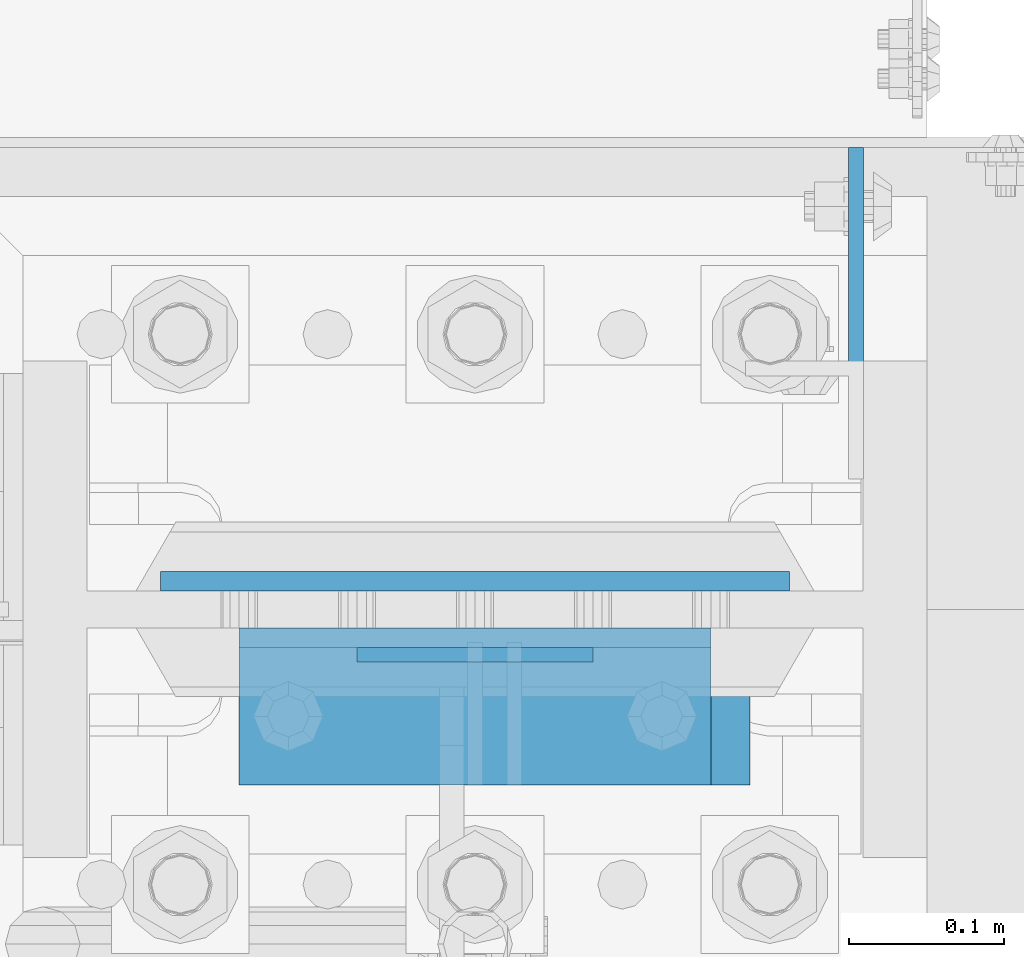
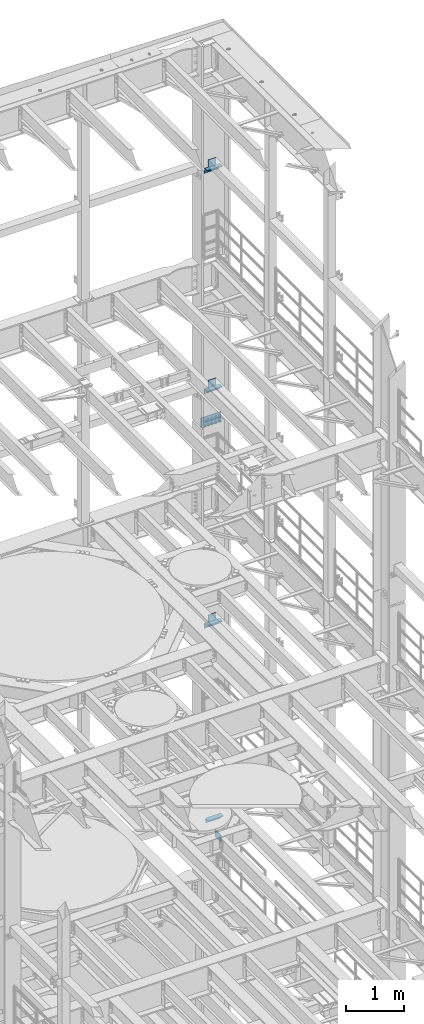
# One storey, part 1354 of 1876: 12 beams, 5 elements without a shape of their own.
"""IFC2X3 building model written with IfcOpenShell, lengths in millimetres."""

from ifc_helpers import new_model, si_unit, frame, origin_with_axes, place, context, subcontext, project, spatial, faceted_brep, material, type_object, element, aggregate, save


model = new_model("IFC2X3")

# Units and contexts
model_context = context("Model", 3, precision=1e-05, world=origin_with_axes())
body_context = subcontext(model_context, "Body", "Model", "MODEL_VIEW")
ifc_project = project(units=[si_unit("LENGTHUNIT", "METRE", prefix="MILLI"), si_unit("AREAUNIT", "SQUARE_METRE"), si_unit("VOLUMEUNIT", "CUBIC_METRE"), si_unit("MASSUNIT", "GRAM", prefix="KILO"), si_unit("TIMEUNIT", "SECOND"), si_unit("PLANEANGLEUNIT", "RADIAN"), si_unit("SOLIDANGLEUNIT", "STERADIAN"), si_unit("THERMODYNAMICTEMPERATUREUNIT", "DEGREE_CELSIUS"), si_unit("LUMINOUSINTENSITYUNIT", "LUMEN")], contexts=[model_context])

# Site, building, storey
site_placement = place(None, origin_with_axes())
site = spatial("IfcSite", under=ifc_project, at=site_placement, CompositionType="ELEMENT")
building_placement = place(site_placement, origin_with_axes())
building = spatial("IfcBuilding", under=site, at=building_placement, Name="Undefined", CompositionType="ELEMENT")
storey_placement = place(building_placement, origin_with_axes())
storey = spatial("IfcBuildingStorey", under=building, at=storey_placement, Name="Undefined", CompositionType="ELEMENT", Elevation=0.0)

# Assembly, beam
assembly_1_placement = place(storey_placement, origin_with_axes())
assembly_1 = element("IfcElementAssembly", 1, at=assembly_1_placement, inside=storey, Name="COLUMN", AssemblyPlace="NOTDEFINED", PredefinedType="RIGID_FRAME")
ifc_material_1 = material(Name="STEEL/A36")
beam_type_1 = type_object("IfcBeamType", PredefinedType="NOTDEFINED")
beam_1_placement = place(assembly_1_placement, frame((7866.20421670226, 13800.1375001356, 5613.4), z_axis=(0.0, 0.0, -1.0), x_axis=(0.0, 1.0, 0.0)))
beam_1 = element("IfcBeam", 2, at=beam_1_placement, type_object=beam_type_1, material=ifc_material_1, Name="PLATE", context=body_context, shape_type="Brep", body=[
    faceted_brep([(0.0, 4.76249999999982, -76.1999999999998), (3.63797880709171e-12, 4.76249999999982, 76.1999969482422), (214.312499998445, 4.76249999993797, 76.2000000000007), (214.312499998445, 4.76249999993797, -76.2000000000007), (3.63797880709171e-12, -4.76249999999982, 76.1999969482422), (214.312499998441, -4.76250000006257, 76.2000000000007), (0.0, -4.76249999999982, -76.1999999999998), (214.312499998441, -4.76250000006257, -76.2000000000007)], [[[0, 1, 2, 3]], [[1, 4, 5, 2]], [[4, 6, 7, 5]], [[6, 0, 3, 7]], [[5, 7, 3, 2]], [[6, 4, 1, 0]]]),
])

assembly_2_placement = place(storey_placement, origin_with_axes())
assembly_2 = element("IfcElementAssembly", 3, at=assembly_2_placement, inside=storey, Name="BEAM", AssemblyPlace="NOTDEFINED", PredefinedType="RIGID_FRAME")
beam_2_placement = place(assembly_2_placement, frame((7696.2, 13686.63125, 19958.05), z_axis=(0.0, 0.0, -1.0), x_axis=(-1.0, 0.0, 0.0)))
beam_2 = element("IfcBeam", 4, at=beam_2_placement, type_object=beam_type_1, material=ifc_material_1, Name="PLATE", context=body_context, shape_type="Brep", body=[
    faceted_brep([(0.0, 4.76249999999982, -76.1999999999998), (3.63797880709171e-12, 4.76249999999982, 76.1999969482422), (152.399993896484, 4.76250000000073, 76.1999969482422), (152.4, 4.76249999999982, -76.1999999999998), (3.63797880709171e-12, -4.76249999999982, 76.1999969482422), (152.399993896484, -4.76250000000073, 76.1999969482422), (0.0, -4.76249999999982, -76.1999999999998), (152.4, -4.76249999999982, -76.1999999999998)], [[[0, 1, 2, 3]], [[4, 5, 2, 1]], [[4, 6, 7, 5]], [[6, 0, 3, 7]], [[5, 7, 3, 2]], [[6, 4, 1, 0]]]),
])

assembly_3_placement = place(storey_placement, origin_with_axes())
assembly_3 = element("IfcElementAssembly", 5, at=assembly_3_placement, inside=storey, Name="BEAM", AssemblyPlace="NOTDEFINED", PredefinedType="RIGID_FRAME")
beam_3_placement = place(assembly_3_placement, frame((7696.2, 13686.63125, 15335.25), z_axis=(0.0, 0.0, -1.0), x_axis=(-1.0, 0.0, 0.0)))
beam_3 = element("IfcBeam", 6, at=beam_3_placement, type_object=beam_type_1, material=ifc_material_1, Name="PLATE", context=body_context, shape_type="Brep", body=[
    faceted_brep([(0.0, 4.76249999999982, -76.1999999999998), (3.63797880709171e-12, 4.76249999999982, 76.1999969482422), (152.399993896484, 4.76250000000073, 76.1999969482422), (152.4, 4.76249999999982, -76.1999999999998), (3.63797880709171e-12, -4.76249999999982, 76.1999969482422), (152.399993896484, -4.76250000000073, 76.1999969482422), (0.0, -4.76249999999982, -76.1999999999998), (152.4, -4.76249999999982, -76.1999999999998)], [[[0, 1, 2, 3]], [[4, 5, 2, 1]], [[4, 6, 7, 5]], [[6, 0, 3, 7]], [[5, 7, 3, 2]], [[6, 4, 1, 0]]]),
])

assembly_4_placement = place(storey_placement, origin_with_axes())
assembly_4 = element("IfcElementAssembly", 7, at=assembly_4_placement, inside=storey, Name="BEAM", AssemblyPlace="NOTDEFINED", PredefinedType="RIGID_FRAME")
beam_4_placement = place(assembly_4_placement, frame((7696.2, 13686.63125, 10420.35), z_axis=(0.0, 0.0, -1.0), x_axis=(-1.0, 0.0, 0.0)))
beam_4 = element("IfcBeam", 8, at=beam_4_placement, type_object=beam_type_1, material=ifc_material_1, Name="PLATE", context=body_context, shape_type="Brep", body=[
    faceted_brep([(0.0, 4.76249999999982, -76.1999999999998), (3.63797880709171e-12, 4.76249999999982, 76.1999969482422), (152.399993896484, 4.76250000000073, 76.1999969482422), (152.4, 4.76249999999982, -76.1999999999998), (3.63797880709171e-12, -4.76249999999982, 76.1999969482422), (152.399993896484, -4.76250000000073, 76.1999969482422), (0.0, -4.76249999999982, -76.1999999999998), (152.4, -4.76249999999982, -76.1999999999998)], [[[0, 1, 2, 3]], [[4, 5, 2, 1]], [[4, 6, 7, 5]], [[6, 0, 3, 7]], [[5, 7, 3, 2]], [[6, 4, 1, 0]]]),
])

# Beam
beam_type_2 = type_object("IfcBeamType", PredefinedType="NOTDEFINED")
beam_5_placement = place(assembly_2_placement, frame((7467.6, 13646.94375, 19877.0875), z_axis=(0.0, -1.0, 0.0), x_axis=(1.0, 0.0, 0.0)))
beam_5 = element("IfcBeam", 9, at=beam_5_placement, type_object=beam_type_2, material=ifc_material_1, Name="PLATE", context=body_context, shape_type="Brep", body=[
    faceted_brep([(0.0, 4.76250000000073, -44.4499999999998), (0.0, 4.76250000000073, 44.4499999999998), (304.799999999999, 4.76250000000073, 44.4499999999998), (304.799999999999, 4.76250000000073, -44.4499999999998), (0.0, -4.76250000000073, 44.4499999999998), (304.799999999999, -4.76250000000073, 44.4499999999998), (0.0, -4.76250000000073, -44.4499999999998), (304.799999999999, -4.76250000000073, -44.4499999999998)], [[[0, 1, 2, 3]], [[1, 4, 5, 2]], [[4, 6, 7, 5]], [[6, 0, 3, 7]], [[5, 7, 3, 2]], [[6, 4, 1, 0]]]),
])

aggregate(assembly_2, [beam_2, beam_5])

beam_6_placement = place(assembly_3_placement, frame((7467.6, 13646.94375, 15254.2875), z_axis=(0.0, -1.0, 0.0), x_axis=(1.0, 0.0, 0.0)))
beam_6 = element("IfcBeam", 10, at=beam_6_placement, type_object=beam_type_2, material=ifc_material_1, Name="PLATE", context=body_context, shape_type="Brep", body=[
    faceted_brep([(0.0, 4.76250000000073, -44.4499999999998), (0.0, 4.76250000000073, 44.4499999999998), (304.799999999999, 4.76250000000073, 44.4499999999998), (304.799999999999, 4.76250000000073, -44.4499999999998), (0.0, -4.76250000000073, 44.4499999999998), (304.799999999999, -4.76250000000073, 44.4499999999998), (0.0, -4.76250000000073, -44.4499999999998), (304.799999999999, -4.76250000000073, -44.4499999999998)], [[[0, 1, 2, 3]], [[1, 4, 5, 2]], [[4, 6, 7, 5]], [[6, 0, 3, 7]], [[5, 7, 3, 2]], [[6, 4, 1, 0]]]),
])

aggregate(assembly_3, [beam_3, beam_6])

beam_7_placement = place(assembly_4_placement, frame((7467.6, 13646.94375, 10339.3875), z_axis=(0.0, -1.0, 0.0), x_axis=(1.0, 0.0, 0.0)))
beam_7 = element("IfcBeam", 11, at=beam_7_placement, type_object=beam_type_2, material=ifc_material_1, Name="PLATE", context=body_context, shape_type="Brep", body=[
    faceted_brep([(0.0, 4.76250000000073, -44.4499999999998), (0.0, 4.76250000000073, 44.4499999999998), (304.799999999999, 4.76250000000073, 44.4499999999998), (304.799999999999, 4.76250000000073, -44.4499999999998), (0.0, -4.76250000000073, 44.4499999999998), (304.799999999999, -4.76250000000073, 44.4499999999998), (0.0, -4.76250000000073, -44.4499999999998), (304.799999999999, -4.76250000000073, -44.4499999999998)], [[[0, 1, 2, 3]], [[1, 4, 5, 2]], [[4, 6, 7, 5]], [[6, 0, 3, 7]], [[5, 7, 3, 2]], [[6, 4, 1, 0]]]),
])

aggregate(assembly_4, [beam_4, beam_7])

# Assembly, beams
assembly_5_placement = place(storey_placement, origin_with_axes())
assembly_5 = element("IfcElementAssembly", 12, at=assembly_5_placement, inside=storey, Name="COLUMN", AssemblyPlace="NOTDEFINED", PredefinedType="RIGID_FRAME")
beam_type_3 = type_object("IfcBeamType", Name="L4X4X3/8", PredefinedType="NOTDEFINED")
beam_8_placement = place(assembly_5_placement, frame((7467.6, 13653.29375, 19821.525), z_axis=(0.0, -1.0, 0.0), x_axis=(1.0, 0.0, 0.0)))
beam_8 = element("IfcBeam", 13, at=beam_8_placement, type_object=beam_type_3, material=ifc_material_1, Name="ANGLE", ObjectType="L4X4X3/8", context=body_context, shape_type="Brep", body=[
    faceted_brep([(0.0, 50.7999999999993, -50.8000000000002), (0.0, 50.7999999999993, 50.8000000000002), (304.799999999999, 50.7999999999993, 50.8000000000002), (304.799999999999, 50.7999999999993, -50.8000000000002), (0.0, 41.2750000000015, 50.8000000000002), (304.799999999999, 41.2750000000015, 50.8000000000002), (0.0, 41.2750000000015, -41.2749999999996), (304.799999999999, 41.2750000000015, -41.2749999999996), (0.0, -50.7999999999993, -41.2749999999996), (304.799999999999, -50.7999999999993, -41.2749999999996), (0.0, -50.7999999999993, -50.8000000000002), (304.799999999999, -50.7999999999993, -50.8000000000002)], [[[0, 1, 2, 3]], [[1, 4, 5, 2]], [[4, 6, 7, 5]], [[6, 8, 9, 7]], [[8, 10, 11, 9]], [[10, 0, 3, 11]], [[5, 7, 9, 11, 3, 2]], [[10, 8, 6, 4, 1, 0]]]),
])
beam_9_placement = place(assembly_5_placement, frame((7467.6, 13653.29375, 15198.725), z_axis=(0.0, -1.0, 0.0), x_axis=(1.0, 0.0, 0.0)))
beam_9 = element("IfcBeam", 14, at=beam_9_placement, type_object=beam_type_3, material=ifc_material_1, Name="ANGLE", ObjectType="L4X4X3/8", context=body_context, shape_type="Brep", body=[
    faceted_brep([(0.0, 50.7999999999993, -50.8000000000002), (0.0, 50.7999999999993, 50.8000000000002), (304.799999999999, 50.7999999999993, 50.8000000000002), (304.799999999999, 50.7999999999993, -50.8000000000002), (0.0, 41.2750000000015, 50.8000000000002), (304.799999999999, 41.2750000000015, 50.8000000000002), (0.0, 41.2750000000015, -41.2749999999996), (304.799999999999, 41.2750000000015, -41.2749999999996), (0.0, -50.7999999999993, -41.2749999999996), (304.799999999999, -50.7999999999993, -41.2749999999996), (0.0, -50.7999999999993, -50.8000000000002), (304.799999999999, -50.7999999999993, -50.8000000000002)], [[[0, 1, 2, 3]], [[1, 4, 5, 2]], [[4, 6, 7, 5]], [[6, 8, 9, 7]], [[8, 10, 11, 9]], [[10, 0, 3, 11]], [[5, 7, 9, 11, 3, 2]], [[10, 8, 6, 4, 1, 0]]]),
])
aggregate(assembly_5, [beam_8, beam_9])

# Beam
beam_10_placement = place(assembly_1_placement, frame((7467.6, 13653.29375, 10283.825), z_axis=(0.0, -1.0, 0.0), x_axis=(1.0, 0.0, 0.0)))
beam_10 = element("IfcBeam", 15, at=beam_10_placement, type_object=beam_type_3, material=ifc_material_1, Name="ANGLE", ObjectType="L4X4X3/8", context=body_context, shape_type="Brep", body=[
    faceted_brep([(0.0, 50.7999999999993, -50.8000000000002), (0.0, 50.7999999999993, 50.8000000000002), (304.799999999999, 50.7999999999993, 50.8000000000002), (304.799999999999, 50.7999999999993, -50.8000000000002), (0.0, 41.2750000000015, 50.8000000000002), (304.799999999999, 41.2750000000015, 50.8000000000002), (0.0, 41.2750000000015, -41.2749999999996), (304.799999999999, 41.2750000000015, -41.2749999999996), (0.0, -50.7999999999993, -41.2749999999996), (304.799999999999, -50.7999999999993, -41.2749999999996), (0.0, -50.7999999999993, -50.8000000000002), (304.799999999999, -50.7999999999993, -50.8000000000002)], [[[0, 1, 2, 3]], [[1, 4, 5, 2]], [[4, 6, 7, 5]], [[6, 8, 9, 7]], [[8, 10, 11, 9]], [[10, 0, 3, 11]], [[5, 7, 9, 11, 3, 2]], [[10, 8, 6, 4, 1, 0]]]),
])

beam_11_placement = place(assembly_1_placement, frame((7493.0, 13653.29375, 6194.425), z_axis=(0.0, -1.0, 0.0), x_axis=(1.0, 0.0, 0.0)))
beam_11 = element("IfcBeam", 16, at=beam_11_placement, type_object=beam_type_3, material=ifc_material_1, Name="ANGLE", ObjectType="L4X4X3/8", context=body_context, shape_type="Brep", body=[
    faceted_brep([(0.0, 50.7999999999993, -50.8000000000002), (0.0, 50.7999999999993, 50.8000000000002), (304.799999999999, 50.7999999999993, 50.8000000000002), (304.799999999999, 50.7999999999993, -50.8000000000002), (0.0, 41.2750000000015, 50.8000000000002), (304.799999999999, 41.2750000000015, 50.8000000000002), (0.0, 41.2750000000015, -41.2749999999996), (304.799999999999, 41.2750000000015, -41.2749999999996), (0.0, -50.7999999999993, -41.2749999999996), (304.799999999999, -50.7999999999993, -41.2749999999996), (0.0, -50.7999999999993, -50.8000000000002), (304.799999999999, -50.7999999999993, -50.8000000000002)], [[[0, 1, 2, 3]], [[1, 4, 5, 2]], [[4, 6, 7, 5]], [[6, 8, 9, 7]], [[8, 10, 11, 9]], [[10, 0, 3, 11]], [[5, 7, 9, 11, 3, 2]], [[10, 8, 6, 4, 1, 0]]]),
])

ifc_material_2 = material(Name="STEEL/A572-50")
beam_type_4 = type_object("IfcBeamType", PredefinedType="NOTDEFINED")
beam_12_placement = place(assembly_1_placement, frame((7620.0, 13734.25625, 14636.75), z_axis=(-1.0, 0.0, 0.0), x_axis=(0.0, 0.0, -1.0)))
beam_12 = element("IfcBeam", 17, at=beam_12_placement, type_object=beam_type_4, material=ifc_material_2, Name="PLATE", context=body_context, shape_type="Brep", body=[
    faceted_brep([(0.0, 6.35000000000036, -203.2), (0.0, 6.35000000000036, 203.2), (209.550000000001, 6.35000000000036, 203.2), (209.550000000001, 6.35000000000036, -203.2), (0.0, -6.35000000000036, 203.2), (209.550000000001, -6.35000000000036, 203.2), (0.0, -6.35000000000036, -203.2), (209.550000000001, -6.35000000000036, -203.2)], [[[0, 1, 2, 3]], [[1, 4, 5, 2]], [[4, 6, 7, 5]], [[6, 0, 3, 7]], [[5, 7, 3, 2]], [[6, 4, 1, 0]]]),
])

aggregate(assembly_1, [beam_1, beam_10, beam_11, beam_12])

save(model, "model.ifc")
